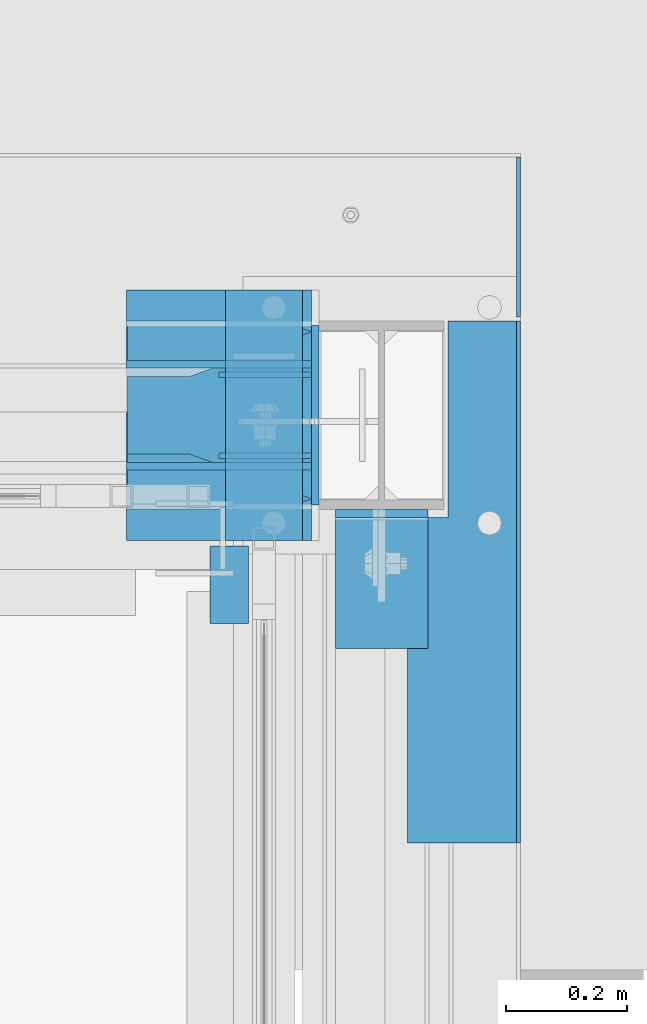
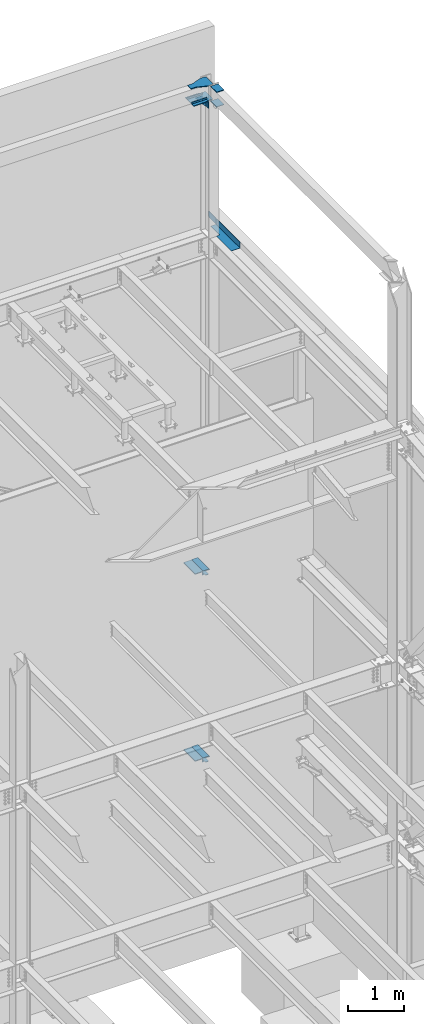
# One storey, part 953 of 1179: 19 beams, 10 elements without a shape of their own.
"""IFC2X3 building model written with IfcOpenShell, lengths in millimetres."""

import ifcopenshell
import ifcopenshell.guid

model = None  # the IFC model being written
_history = None  # IfcOwnerHistory: only IFC2X3 demands one
_inside = {}  # id of a spatial element -> (the spatial element, [elements in it])
_under = {}  # id of a project, library or spatial element -> (it, [spatial elements below it])
_declared = {}  # id of a project -> (the project, [libraries it declares])
_typed = {}  # id of a type object -> (the type object, [elements of that type])
_made_of = {}  # id of a material, layer set ... -> (it, [elements and type objects made of it])


def new_model(schema):
    """Start an empty IFC model of exactly this schema.

    Asked for "IFC4X3", IfcOpenShell would pick the latest addendum, in which some entities
    have other attributes; the version numbers below select the first issue.
    IFC2X3 requires an IfcOwnerHistory on every rooted entity: one is made here for all.
    """
    global model, _history
    if schema == "IFC4X3":
        model = ifcopenshell.file(schema_version=(4, 3, 0, 0))
    else:
        model = ifcopenshell.file(schema=schema)
    _inside.clear()
    _under.clear()
    _declared.clear()
    _typed.clear()
    _made_of.clear()
    _history = None
    if model.schema == "IFC2X3":
        org = make("IfcOrganization", Name="unknown")
        user = make(
            "IfcPersonAndOrganization",
            ThePerson=make("IfcPerson", FamilyName="unknown"),
            TheOrganization=org,
        )
        app = make(
            "IfcApplication",
            ApplicationDeveloper=org,
            Version="unknown",
            ApplicationFullName="unknown",
            ApplicationIdentifier="unknown",
        )
        _history = make(
            "IfcOwnerHistory",
            OwningUser=user,
            OwningApplication=app,
            ChangeAction="ADDED",
            CreationDate=0,
        )
    return model


def make(cls, **values):
    """One entity of the class cls with the attributes given. An attribute that is None is left unset."""
    return model.create_entity(
        cls, **{name: value for name, value in values.items() if value is not None}
    )


def rooted(cls, **values):
    """An entity with a GlobalId (a new one), such as an element, a storey or a relation."""
    return make(cls, GlobalId=ifcopenshell.guid.new(), OwnerHistory=_history, **values)


def si_unit(unit_type, name, prefix=None):
    """IfcSIUnit, for example si_unit("LENGTHUNIT", "METRE", prefix="MILLI")."""
    return make("IfcSIUnit", UnitType=unit_type, Prefix=prefix, Name=name)


def assignment(units):
    """IfcUnitAssignment: the units of a project."""
    return None if units is None else make("IfcUnitAssignment", Units=units)


def point(xyz):
    """IfcCartesianPoint."""
    return None if xyz is None else make("IfcCartesianPoint", Coordinates=xyz)


def direction(xyz):
    """IfcDirection."""
    return None if xyz is None else make("IfcDirection", DirectionRatios=xyz)


def frame(location, z_axis=None, x_axis=None):
    """IfcAxis2Placement3D, a coordinate frame: its origin and axes. An axis left out is left unset."""
    return make(
        "IfcAxis2Placement3D",
        Location=point(location),
        Axis=direction(z_axis),
        RefDirection=direction(x_axis),
    )


def origin_with_axes():
    """The frame at (0, 0, 0) with the z axis (0, 0, 1) and the x axis (1, 0, 0) written out."""
    return frame((0.0, 0.0, 0.0), z_axis=(0.0, 0.0, 1.0), x_axis=(1.0, 0.0, 0.0))


def place(relative_to, where):
    """IfcLocalPlacement: puts the frame where relative to a parent placement (None: the world)."""
    return make(
        "IfcLocalPlacement", PlacementRelTo=relative_to, RelativePlacement=where
    )


def context(
    kind, dimensions, precision=None, world=None, true_north=None, identifier=None
):
    """IfcGeometricRepresentationContext, for example the 3D "Model" context."""
    return make(
        "IfcGeometricRepresentationContext",
        ContextIdentifier=identifier,
        ContextType=kind,
        CoordinateSpaceDimension=dimensions,
        Precision=precision,
        WorldCoordinateSystem=world,
        TrueNorth=true_north,
    )


def subcontext(parent, identifier, kind, view, scale=None):
    """IfcGeometricRepresentationSubContext, for example "Body" below "Model"."""
    return make(
        "IfcGeometricRepresentationSubContext",
        ContextIdentifier=identifier,
        ContextType=kind,
        ParentContext=parent,
        TargetScale=scale,
        TargetView=view,
    )


def project(units=None, contexts=None):
    """IfcProject with its units and contexts."""
    return rooted(
        "IfcProject",
        Name="project",
        RepresentationContexts=contexts,
        UnitsInContext=assignment(units),
    )


def spatial(cls, under=None, at=None, **own):
    """A site, building, storey or space (cls), placed at a placement, below another one or the project."""
    s = rooted(cls, ObjectPlacement=at, **own)
    if under is not None:
        _under.setdefault(under.id(), (under, []))[1].append(s)
    return s


def faces_of(points, faces, orient=None, outer=None):
    """IfcFace entities. A face is a list of loops; a loop is a list of indices into points, from 0.

    orient and outer hold one flag for each loop. By default every Orientation is true, the
    first loop of a face is its IfcFaceOuterBound and the others are IfcFaceBound.
    """
    made = []
    for i, loops in enumerate(faces):
        bounds = []
        for j, loop in enumerate(loops):
            is_outer = j == 0 if outer is None else outer[i][j]
            bounds.append(
                make(
                    "IfcFaceOuterBound" if is_outer else "IfcFaceBound",
                    Bound=make("IfcPolyLoop", Polygon=[points[k] for k in loop]),
                    Orientation=True if orient is None else orient[i][j],
                )
            )
        made.append(make("IfcFace", Bounds=bounds))
    return made


def faceted_brep(points, faces, orient=None, outer=None, voids=None):
    """IfcFacetedBrep: a solid bounded by flat faces; with voids (closed shells), ...WithVoids."""
    shared = [point(p) for p in points]
    hull = make("IfcClosedShell", CfsFaces=faces_of(shared, faces, orient, outer))
    if voids is None:
        return make("IfcFacetedBrep", Outer=hull)
    return make(
        "IfcFacetedBrepWithVoids",
        Outer=hull,
        Voids=[
            make(cls, CfsFaces=faces_of(shared, fs, o, b)) for cls, fs, o, b in voids
        ],
    )


def shape(context_of_items, identifier, shape_type, items):
    """IfcShapeRepresentation: the items that make up one representation, for example the "Body"."""
    return make(
        "IfcShapeRepresentation",
        ContextOfItems=context_of_items,
        RepresentationIdentifier=identifier,
        RepresentationType=shape_type,
        Items=items,
    )


def material(Name=None, Category=None):
    """IfcMaterial."""
    return make("IfcMaterial", Name=Name, Category=Category)


def made_of(thing, what):
    """Note that an element or type object is made of a material, layer set ...; save() writes the relation."""
    if what is not None:
        _made_of.setdefault(what.id(), (what, []))[1].append(thing)
    return thing


def type_object(cls, material=None, **own):
    """A type object (cls), such as IfcWallType, which elements share."""
    return made_of(rooted(cls, **own), material)


def element(
    cls,
    number,
    at=None,
    inside=None,
    cuts=None,
    type_object=None,
    material=None,
    context=None,
    identifier="Body",
    shape_type=None,
    held_by="IfcProductDefinitionShape",
    body=None,
    shapes=None,
    **own,
):
    """One element of the class cls, such as IfcWall. Its Tag is "e" and its number.

    at: its placement. inside: the storey or other place that contains it. cuts: it is an
    opening in that element (IfcRelVoidsElement). A single representation is given by context,
    identifier, shape_type and body (its items); several are given by shapes. held_by: the class
    of the entity that holds the representations. save() writes the other relations.
    """
    e = rooted(cls, Tag="e%d" % number, ObjectPlacement=at, **own)
    if body is not None:
        shapes = [shape(context, identifier, shape_type, body)]
    if shapes is not None:
        e.Representation = make(held_by, Representations=shapes)
    if inside is not None:
        _inside.setdefault(inside.id(), (inside, []))[1].append(e)
    if cuts is not None:
        rooted(
            "IfcRelVoidsElement", RelatingBuildingElement=cuts, RelatedOpeningElement=e
        )
    if type_object is not None:
        _typed.setdefault(type_object.id(), (type_object, []))[1].append(e)
    return made_of(e, material)


def aggregate(whole, parts):
    """IfcRelAggregates: a whole, such as a stair, and the parts it consists of."""
    return rooted("IfcRelAggregates", RelatingObject=whole, RelatedObjects=parts)


def save(model, path):
    """Write the relations noted so far, then the file.

    IfcRelAggregates (storeys below a building ...), IfcRelContainedInSpatialStructure (elements
    in a storey), IfcRelDefinesByType, IfcRelAssociatesMaterial and IfcRelDeclares: one each for
    every whole, place, type object, material and project.
    """
    for whole, parts in _under.values():
        aggregate(whole, parts)
    for where, things in _inside.values():
        rooted(
            "IfcRelContainedInSpatialStructure",
            RelatedElements=things,
            RelatingStructure=where,
        )
    for kind, things in _typed.values():
        rooted("IfcRelDefinesByType", RelatedObjects=things, RelatingType=kind)
    for what, things in _made_of.values():
        rooted("IfcRelAssociatesMaterial", RelatedObjects=things, RelatingMaterial=what)
    for by, libraries in _declared.values():
        rooted("IfcRelDeclares", RelatingContext=by, RelatedDefinitions=libraries)
    model.write(path)


model = new_model("IFC2X3")

# Units and contexts
model_context = context("Model", 3, precision=1e-05, world=origin_with_axes())
body_context = subcontext(model_context, "Body", "Model", "MODEL_VIEW")
ifc_project = project(units=[si_unit("LENGTHUNIT", "METRE", prefix="MILLI"), si_unit("AREAUNIT", "SQUARE_METRE"), si_unit("VOLUMEUNIT", "CUBIC_METRE"), si_unit("MASSUNIT", "GRAM", prefix="KILO"), si_unit("TIMEUNIT", "SECOND"), si_unit("PLANEANGLEUNIT", "RADIAN"), si_unit("SOLIDANGLEUNIT", "STERADIAN"), si_unit("THERMODYNAMICTEMPERATUREUNIT", "DEGREE_CELSIUS"), si_unit("LUMINOUSINTENSITYUNIT", "LUMEN")], contexts=[model_context])

# Site, building, storey
site_placement = place(None, origin_with_axes())
site = spatial("IfcSite", under=ifc_project, at=site_placement, CompositionType="ELEMENT")
building_placement = place(site_placement, origin_with_axes())
building = spatial("IfcBuilding", under=site, at=building_placement, Name="Undefined", CompositionType="ELEMENT")
storey_placement = place(building_placement, origin_with_axes())
storey = spatial("IfcBuildingStorey", under=building, at=storey_placement, Name="Undefined", CompositionType="ELEMENT", Elevation=0.0)

# Assembly, beam
assembly_1_placement = place(storey_placement, origin_with_axes())
assembly_1 = element("IfcElementAssembly", 1, at=assembly_1_placement, inside=storey, Name="BEAM", AssemblyPlace="NOTDEFINED", PredefinedType="RIGID_FRAME")
ifc_material = material(Name="STEEL/A36")
beam_type_1 = type_object("IfcBeamType", PredefinedType="NOTDEFINED")
beam_1_placement = place(assembly_1_placement, frame((24350.663, 40924.1625, 13122.275), z_axis=(0.0, -1.0, 0.0), x_axis=(1.0, 0.0, 0.0)))
beam_1 = element("IfcBeam", 2, at=beam_1_placement, type_object=beam_type_1, material=ifc_material, Name="BENT_PLATE", context=body_context, shape_type="Brep", body=[
    faceted_brep([(66.6744999999974, -3.17499999999927, -106.36250000001), (66.6744999999974, 3.17499999999927, -106.36250000001), (66.6744999999974, 3.17499999999927, -430.212500000001), (66.6744999999974, -3.17499999999927, -430.212500000001), (0.0, -3.17499999999927, -106.36250000001), (0.0, 3.17499999999927, -106.36250000001), (179.387000000002, 3.17499999999927, 430.212500000001), (0.0, 3.17499999999927, 430.212500000001), (0.0, -3.17499999999927, 430.212500000001), (185.737000000001, -3.17499999999927, 430.212500000001), (185.737000000001, 130.175000000001, 430.212500000001), (179.387000000002, 130.175000000001, 430.212500000001), (179.387000000002, 3.17499999999927, -430.212500000001), (179.387000000002, 130.175000000001, -430.212500000001), (185.737000000001, 130.175000000001, -430.212500000001), (185.737000000001, -3.17499999999927, -430.212500000001)], [[[0, 1, 2, 3]], [[4, 5, 1, 0]], [[6, 7, 8, 9, 10, 11]], [[12, 6, 11, 13]], [[10, 14, 13, 11]], [[9, 15, 14, 10]], [[12, 13, 14, 15, 3, 2]], [[7, 6, 12, 2, 1, 5]], [[8, 7, 5, 4]], [[15, 9, 8, 4, 0, 3]]]),
])
aggregate(assembly_1, [beam_1])

# Assembly, beams
assembly_2_placement = place(storey_placement, origin_with_axes())
assembly_2 = element("IfcElementAssembly", 3, at=assembly_2_placement, inside=storey, Name="COLUMN", AssemblyPlace="NOTDEFINED", PredefinedType="RIGID_FRAME")
beam_type_2 = type_object("IfcBeamType", PredefinedType="NOTDEFINED")
beam_2_placement = place(assembly_2_placement, frame((24198.2625, 41346.4375, 16030.575), z_axis=(0.0, 0.0, 1.0), x_axis=(0.0, -1.0, 0.0)))
beam_2 = element("IfcBeam", 4, at=beam_2_placement, type_object=beam_type_2, material=ifc_material, Name="PLATE", context=body_context, shape_type="Brep", body=[
    faceted_brep([(-7.27595761418343e-12, 6.35000000000036, -76.1999999999971), (0.0, 6.35000000000036, 76.2000000000044), (295.274999999994, 6.34999999999854, 76.2000000000007), (295.274999999994, 6.34999999999854, -76.2000000000007), (0.0, -6.35000000000036, 76.2000000000044), (295.274999999994, -6.34999999999854, 76.2000000000007), (7.27595761418343e-12, -6.35000000000036, -76.1999999999971), (295.274999999994, -6.34999999999854, -76.2000000000007)], [[[0, 1, 2, 3]], [[1, 4, 5, 2]], [[4, 6, 7, 5]], [[6, 0, 3, 7]], [[5, 7, 3, 2]], [[6, 4, 1, 0]]]),
])
beam_3_placement = place(assembly_2_placement, frame((24307.8, 40814.6250061035, 16116.3), z_axis=(1.0, 0.0, 0.0), x_axis=(0.0, 1.0, 0.0)))
beam_3 = element("IfcBeam", 5, at=beam_3_placement, type_object=beam_type_2, material=ifc_material, Name="PLATE", context=body_context, shape_type="Brep", body=[
    faceted_brep([(215.900000000001, 6.35000000000036, 76.2000000000007), (228.599999999999, -6.35000000000036, 76.2000000000007), (228.599999999999, -6.35000000000036, -76.2000000000007), (215.900000000001, 6.35000000000036, -76.2000000000007), (-7.27595761418343e-12, 6.35000000000036, -76.1999999999971), (0.0, 6.35000000000036, 76.2000000000044), (0.0, -6.35000000000036, 76.2000000000044), (7.27595761418343e-12, -6.35000000000036, -76.1999999999971)], [[[0, 1, 2, 3]], [[4, 5, 0, 3]], [[5, 6, 1, 0]], [[6, 7, 2, 1]], [[7, 4, 3, 2]], [[7, 6, 5, 4]]]),
])
beam_4_placement = place(assembly_2_placement, frame((24307.8, 40814.6250059853, 16435.3875), z_axis=(1.0, 0.0, 0.0), x_axis=(0.0, 1.0, 0.0)))
beam_4 = element("IfcBeam", 6, at=beam_4_placement, type_object=beam_type_2, material=ifc_material, Name="PLATE", context=body_context, shape_type="Brep", body=[
    faceted_brep([(215.900000000001, 6.35000000000036, 76.2000000000007), (228.599999999999, -6.35000000000036, 76.2000000000007), (228.599999999999, -6.35000000000036, -76.2000000000007), (215.900000000001, 6.35000000000036, -76.2000000000007), (-7.27595761418343e-12, 6.35000000000036, -76.1999999999971), (0.0, 6.35000000000036, 76.2000000000044), (0.0, -6.35000000000036, 76.2000000000044), (7.27595761418343e-12, -6.35000000000036, -76.1999999999971)], [[[0, 1, 2, 3]], [[4, 5, 0, 3]], [[5, 6, 1, 0]], [[6, 7, 2, 1]], [[7, 4, 3, 2]], [[7, 6, 5, 4]]]),
])
beam_type_3 = type_object("IfcBeamType", PredefinedType="NOTDEFINED")
beam_5_placement = place(assembly_2_placement, frame((24039.5125, 40992.425, 5921.375), z_axis=(1.0, 0.0, 0.0), x_axis=(0.0, 1.0, 0.0)))
beam_5 = element("IfcBeam", 7, at=beam_5_placement, type_object=beam_type_3, material=ifc_material, Name="PLATE", context=body_context, shape_type="Brep", body=[
    faceted_brep([(0.0, 9.52500000000146, -152.4), (0.0, 9.52500000000146, 152.4), (412.75, 9.52499999999964, 152.400000000001), (412.75, 9.52499999999964, -152.400000000001), (0.0, -9.52500000000146, 152.4), (412.75, -9.52499999999964, 152.400000000001), (0.0, -9.52500000000146, -152.4), (412.75, -9.52499999999964, -152.400000000001)], [[[0, 1, 2, 3]], [[1, 4, 5, 2]], [[4, 6, 7, 5]], [[6, 0, 3, 7]], [[5, 7, 3, 2]], [[6, 4, 1, 0]]]),
])
beam_6_placement = place(assembly_2_placement, frame((24039.5125, 40992.425, 1835.15), z_axis=(1.0, 0.0, 0.0), x_axis=(0.0, 1.0, 0.0)))
beam_6 = element("IfcBeam", 8, at=beam_6_placement, type_object=beam_type_3, material=ifc_material, Name="PLATE", context=body_context, shape_type="Brep", body=[
    faceted_brep([(0.0, 9.52500000000146, -152.4), (0.0, 9.52500000000146, 152.4), (412.75, 9.52499999999964, 152.400000000001), (412.75, 9.52499999999964, -152.400000000001), (0.0, -9.52500000000146, 152.4), (412.75, -9.52499999999964, 152.400000000001), (0.0, -9.52500000000146, -152.4), (412.75, -9.52499999999964, -152.400000000001)], [[[0, 1, 2, 3]], [[1, 4, 5, 2]], [[4, 6, 7, 5]], [[6, 0, 3, 7]], [[5, 7, 3, 2]], [[6, 4, 1, 0]]]),
])

# Assembly, beam
assembly_3_placement = place(storey_placement, origin_with_axes())
assembly_3 = element("IfcElementAssembly", 9, at=assembly_3_placement, inside=storey, Name="STAIR", AssemblyPlace="NOTDEFINED", PredefinedType="RIGID_FRAME")
beam_type_4 = type_object("IfcBeamType", Name="L5X3X3/8", PredefinedType="NOTDEFINED")
beam_7_placement = place(assembly_3_placement, frame((24025.2250004165, 40919.4, 5899.14999999934), z_axis=(0.0, -1.0, 0.0), x_axis=(1.0, 0.0, 0.0)))
beam_7 = element("IfcBeam", 10, at=beam_7_placement, type_object=beam_type_4, material=ifc_material, Name="ANGLE", ObjectType="L5X3X3/8", context=body_context, shape_type="Brep", body=[
    faceted_brep([(0.0, 38.0999999999985, -63.5), (0.0, 38.1000000000004, 63.5), (63.5, 38.1000000000004, 63.5), (63.5, 38.1000000000004, -63.5), (0.0, 28.5749999999998, 63.5), (63.5, 28.5749999999998, 63.5), (0.0, 28.5749999999998, -53.9749999999985), (63.5, 28.5749999999998, -53.9749999999985), (0.0, -38.1000000000004, -53.9749999999985), (63.5, -38.1000000000004, -53.9749999999985), (0.0, -38.1000000000004, -63.5), (63.5, -38.1000000000004, -63.5)], [[[0, 1, 2, 3]], [[1, 4, 5, 2]], [[4, 6, 7, 5]], [[6, 8, 9, 7]], [[8, 10, 11, 9]], [[10, 0, 3, 11]], [[5, 7, 9, 11, 3, 2]], [[10, 8, 6, 4, 1, 0]]]),
])
aggregate(assembly_3, [beam_7])

assembly_4_placement = place(storey_placement, origin_with_axes())
assembly_4 = element("IfcElementAssembly", 11, at=assembly_4_placement, inside=storey, Name="STAIR", AssemblyPlace="NOTDEFINED", PredefinedType="RIGID_FRAME")
beam_8_placement = place(assembly_4_placement, frame((24025.2250004165, 40919.4, 1812.92499999934), z_axis=(0.0, -1.0, 0.0), x_axis=(1.0, 0.0, 0.0)))
beam_8 = element("IfcBeam", 12, at=beam_8_placement, type_object=beam_type_4, material=ifc_material, Name="ANGLE", ObjectType="L5X3X3/8", context=body_context, shape_type="Brep", body=[
    faceted_brep([(0.0, 38.0999999999985, -63.5), (0.0, 38.1000000000004, 63.5), (63.5, 38.1000000000004, 63.5), (63.5, 38.1000000000004, -63.5), (0.0, 28.5749999999998, 63.5), (63.5, 28.5749999999998, 63.5), (0.0, 28.5749999999998, -53.9749999999985), (63.5, 28.5749999999998, -53.9749999999985), (0.0, -38.1000000000004, -53.9749999999985), (63.5, -38.1000000000004, -53.9749999999985), (0.0, -38.1000000000004, -63.5), (63.5, -38.1000000000004, -63.5)], [[[0, 1, 2, 3]], [[1, 4, 5, 2]], [[4, 6, 7, 5]], [[6, 8, 9, 7]], [[8, 10, 11, 9]], [[10, 0, 3, 11]], [[5, 7, 9, 11, 3, 2]], [[10, 8, 6, 4, 1, 0]]]),
])
aggregate(assembly_4, [beam_8])

assembly_5_placement = place(storey_placement, origin_with_axes())
assembly_5 = element("IfcElementAssembly", 13, at=assembly_5_placement, inside=storey, Name="LAYER", AssemblyPlace="NOTDEFINED", PredefinedType="RIGID_FRAME")
beam_type_5 = type_object("IfcBeamType", PredefinedType="NOTDEFINED")
beam_9_placement = place(assembly_5_placement, frame((24114.125, 40992.425, 5932.4875), z_axis=(1.0, 0.0, 0.0), x_axis=(0.0, 1.0, 0.0)))
beam_9 = element("IfcBeam", 14, at=beam_9_placement, type_object=beam_type_5, material=ifc_material, Name="LAYER", context=body_context, shape_type="Brep", body=[
    faceted_brep([(0.0, 1.58749999999964, -63.5), (0.0, 1.58749999999964, 63.5), (412.75, 1.58749999999964, 63.5), (412.75, 1.58749999999964, -63.5), (0.0, -1.58749999999964, 63.5), (412.75, -1.58749999999964, 63.5), (0.0, -1.58749999999964, -63.5), (412.75, -1.58749999999964, -63.5)], [[[0, 1, 2, 3]], [[1, 4, 5, 2]], [[4, 6, 7, 5]], [[6, 0, 3, 7]], [[5, 7, 3, 2]], [[6, 4, 1, 0]]]),
])
aggregate(assembly_5, [beam_9])

assembly_6_placement = place(storey_placement, origin_with_axes())
assembly_6 = element("IfcElementAssembly", 15, at=assembly_6_placement, inside=storey, Name="LAYER", AssemblyPlace="NOTDEFINED", PredefinedType="RIGID_FRAME")
beam_10_placement = place(assembly_6_placement, frame((24114.125, 40992.425, 5935.6625), z_axis=(1.0, 0.0, 0.0), x_axis=(0.0, 1.0, 0.0)))
beam_10 = element("IfcBeam", 16, at=beam_10_placement, type_object=beam_type_5, material=ifc_material, Name="LAYER", context=body_context, shape_type="Brep", body=[
    faceted_brep([(0.0, 1.58749999999964, -63.5), (0.0, 1.58749999999964, 63.5), (412.75, 1.58749999999964, 63.5), (412.75, 1.58749999999964, -63.5), (0.0, -1.58749999999964, 63.5), (412.75, -1.58749999999964, 63.5), (0.0, -1.58749999999964, -63.5), (412.75, -1.58749999999964, -63.5)], [[[0, 1, 2, 3]], [[1, 4, 5, 2]], [[4, 6, 7, 5]], [[6, 0, 3, 7]], [[5, 7, 3, 2]], [[6, 4, 1, 0]]]),
])
aggregate(assembly_6, [beam_10])

assembly_7_placement = place(storey_placement, origin_with_axes())
assembly_7 = element("IfcElementAssembly", 17, at=assembly_7_placement, inside=storey, Name="LAYER", AssemblyPlace="NOTDEFINED", PredefinedType="RIGID_FRAME")
beam_11_placement = place(assembly_7_placement, frame((24114.125, 40992.425, 1846.2625), z_axis=(1.0, 0.0, 0.0), x_axis=(0.0, 1.0, 0.0)))
beam_11 = element("IfcBeam", 18, at=beam_11_placement, type_object=beam_type_5, material=ifc_material, Name="LAYER", context=body_context, shape_type="Brep", body=[
    faceted_brep([(0.0, 1.58749999999964, -63.5), (0.0, 1.58749999999964, 63.5), (412.75, 1.58749999999964, 63.5), (412.75, 1.58749999999964, -63.5), (0.0, -1.58749999999964, 63.5), (412.75, -1.58749999999964, 63.5), (0.0, -1.58749999999964, -63.5), (412.75, -1.58749999999964, -63.5)], [[[0, 1, 2, 3]], [[1, 4, 5, 2]], [[4, 6, 7, 5]], [[6, 0, 3, 7]], [[5, 7, 3, 2]], [[6, 4, 1, 0]]]),
])
aggregate(assembly_7, [beam_11])

assembly_8_placement = place(storey_placement, origin_with_axes())
assembly_8 = element("IfcElementAssembly", 19, at=assembly_8_placement, inside=storey, Name="LAYER", AssemblyPlace="NOTDEFINED", PredefinedType="RIGID_FRAME")
beam_12_placement = place(assembly_8_placement, frame((24114.125, 40992.425, 1849.4375), z_axis=(1.0, 0.0, 0.0), x_axis=(0.0, 1.0, 0.0)))
beam_12 = element("IfcBeam", 20, at=beam_12_placement, type_object=beam_type_5, material=ifc_material, Name="LAYER", context=body_context, shape_type="Brep", body=[
    faceted_brep([(0.0, 1.58749999999964, -63.5), (0.0, 1.58749999999964, 63.5), (412.75, 1.58749999999964, 63.5), (412.75, 1.58749999999964, -63.5), (0.0, -1.58749999999964, 63.5), (412.75, -1.58749999999964, 63.5), (0.0, -1.58749999999964, -63.5), (412.75, -1.58749999999964, -63.5)], [[[0, 1, 2, 3]], [[1, 4, 5, 2]], [[4, 6, 7, 5]], [[6, 0, 3, 7]], [[5, 7, 3, 2]], [[6, 4, 1, 0]]]),
])
aggregate(assembly_8, [beam_12])

assembly_9_placement = place(storey_placement, origin_with_axes())
assembly_9 = element("IfcElementAssembly", 21, at=assembly_9_placement, inside=storey, Name="BEAM", AssemblyPlace="NOTDEFINED", PredefinedType="RIGID_FRAME")
beam_type_6 = type_object("IfcBeamType", PredefinedType="NOTDEFINED")
beam_13_placement = place(assembly_9_placement, frame((24533.226, 41360.725, 13188.9500061035), z_axis=(0.0, 0.0, 1.0), x_axis=(0.0, 1.0, 0.0)))
beam_13 = element("IfcBeam", 22, at=beam_13_placement, type_object=beam_type_6, material=ifc_material, Name="PLATE", context=body_context, shape_type="Brep", body=[
    faceted_brep([(263.524999994857, -3.17499999999927, -44.4500000000007), (244.474999994854, -3.17499999999927, -63.5), (244.474999994854, 3.17499999999927, -63.5), (263.524999994857, 3.17499999999927, -44.4500000000007), (0.0, 3.17499999999927, -63.5), (0.0, 3.17499999999927, 63.5), (263.524999994857, 3.17499999999927, 63.5), (0.0, -3.17499999999927, 63.5), (263.524999994857, -3.17499999999927, 63.5), (0.0, -3.17499999999927, -63.5)], [[[0, 1, 2, 3]], [[4, 5, 6, 3, 2]], [[5, 7, 8, 6]], [[8, 7, 9, 1, 0]], [[9, 4, 2, 1]], [[6, 8, 0, 3]], [[9, 7, 5, 4]]]),
])
aggregate(assembly_9, [beam_13])

# Beam
beam_type_7 = type_object("IfcBeamType", PredefinedType="NOTDEFINED")
beam_14_placement = place(assembly_2_placement, frame((23887.1125, 41282.9375, 16141.7), z_axis=(0.0, 0.0, 1.0), x_axis=(1.0, 0.0, 0.0)))
beam_14 = element("IfcBeam", 23, at=beam_14_placement, type_object=beam_type_7, material=ifc_material, Name="PLATE", context=body_context, shape_type="Brep", body=[
    faceted_brep([(0.0, 6.34999999999854, -19.0499999999993), (0.0, 6.35000000000036, 19.0499999999993), (317.5, 6.34999999999854, 19.0499999999993), (317.5, 6.34999999999854, -19.0499999999993), (0.0, -6.35000000000036, 19.0499999999993), (317.5, -6.34999999999854, 19.0499999999993), (0.0, -6.34999999999854, -19.0499999999993), (317.5, -6.34999999999854, -19.0499999999993)], [[[0, 1, 2, 3]], [[1, 4, 5, 2]], [[4, 6, 7, 5]], [[6, 0, 3, 7]], [[5, 7, 3, 2]], [[6, 4, 1, 0]]]),
])

beam_15_placement = place(assembly_2_placement, frame((23887.1125, 41114.6625, 16141.7), z_axis=(0.0, 0.0, 1.0), x_axis=(1.0, 0.0, 0.0)))
beam_15 = element("IfcBeam", 24, at=beam_15_placement, type_object=beam_type_7, material=ifc_material, Name="PLATE", context=body_context, shape_type="Brep", body=[
    faceted_brep([(0.0, 6.34999999999854, -19.0499999999993), (0.0, 6.35000000000036, 19.0499999999993), (317.5, 6.34999999999854, 19.0499999999993), (317.5, 6.34999999999854, -19.0499999999993), (0.0, -6.35000000000036, 19.0499999999993), (317.5, -6.34999999999854, 19.0499999999993), (0.0, -6.34999999999854, -19.0499999999993), (317.5, -6.34999999999854, -19.0499999999993)], [[[0, 1, 2, 3]], [[1, 4, 5, 2]], [[4, 6, 7, 5]], [[6, 0, 3, 7]], [[5, 7, 3, 2]], [[6, 4, 1, 0]]]),
])

beam_type_8 = type_object("IfcBeamType", PredefinedType="NOTDEFINED")
beam_16_placement = place(assembly_2_placement, frame((24039.5125, 41265.475, 16030.575), z_axis=(0.0, 0.0, 1.0), x_axis=(1.0, 0.0, 0.0)))
beam_16 = element("IfcBeam", 25, at=beam_16_placement, type_object=beam_type_8, material=ifc_material, Name="PLATE", context=body_context, shape_type="Brep", body=[
    faceted_brep([(152.4, -4.76249999999709, 76.2), (152.4, -4.76249999999709, -76.2), (152.4, 4.76249999999709, -76.2), (152.4, 4.76249999999709, 76.2), (0.0, 4.76249999999982, 76.1999999999971), (0.0, -4.76249999999982, 76.1999999999971)], [[[0, 1, 2, 3]], [[3, 2, 4]], [[4, 5, 0, 3]], [[0, 5, 1]], [[4, 2, 1, 5]]]),
])

beam_17_placement = place(assembly_2_placement, frame((24039.5125, 41132.125, 16030.575), z_axis=(0.0, 0.0, 1.0), x_axis=(1.0, 0.0, 0.0)))
beam_17 = element("IfcBeam", 26, at=beam_17_placement, type_object=beam_type_8, material=ifc_material, Name="PLATE", context=body_context, shape_type="Brep", body=[
    faceted_brep([(152.4, -4.76249999999709, 76.2), (152.4, -4.76249999999709, -76.2), (152.4, 4.76249999999709, -76.2), (152.4, 4.76249999999709, 76.2), (0.0, 4.76249999999982, 76.1999999999971), (0.0, -4.76249999999982, 76.1999999999971)], [[[0, 1, 2, 3]], [[3, 2, 4]], [[4, 5, 0, 3]], [[0, 5, 1]], [[4, 2, 1, 5]]]),
])

beam_type_9 = type_object("IfcBeamType", PredefinedType="NOTDEFINED")
beam_18_placement = place(assembly_2_placement, frame((23888.7, 41198.8, 16114.7125), z_axis=(0.0, -1.0, 0.0), x_axis=(1.0, 0.0, 0.0)))
beam_18 = element("IfcBeam", 27, at=beam_18_placement, type_object=beam_type_9, material=ifc_material, Name="PLATE", context=body_context, shape_type="Brep", body=[
    faceted_brep([(414.337500000005, -7.9375, -115.887500012301), (392.112500000007, -7.9375, -138.112500017691), (392.112500000007, 7.9375, -138.112500017691), (414.337500000005, 7.9375, -115.887500012301), (414.337500000005, 7.9375, 115.887500762939), (392.112500000007, 7.9375, 138.112500762938), (392.112500000007, -7.9375, 138.112500762938), (414.337500000005, -7.9375, 115.887500762939), (241.300006103491, -7.9375, -155.575000000001), (241.300006103491, 7.9375, -155.575000000001), (304.79998778872, 7.9375, -138.112500038278), (304.79998778872, -7.9375, -138.112500038278), (0.0, -7.9375, -155.575000000001), (0.0, -7.9375, 155.575000000001), (0.0, 7.9375, 155.575000000001), (0.0, 7.9375, -155.575000000001), (241.300006103513, -7.9375, 155.575000000001), (241.300006103513, 7.9375, 155.575000000001), (304.799990844724, -7.9375, 138.112500762938), (304.799990844724, 7.9375, 138.112500762938)], [[[0, 1, 2, 3]], [[4, 5, 6, 7]], [[8, 9, 10, 11]], [[11, 10, 2, 1]], [[12, 13, 14, 15]], [[14, 13, 16, 17]], [[18, 19, 17, 16]], [[19, 18, 6, 5]], [[4, 7, 0, 3]], [[10, 9, 15, 14, 17, 19, 5, 4, 3, 2]], [[12, 15, 9, 8]], [[7, 6, 18, 16, 13, 12, 8, 11, 1, 0]]]),
])

aggregate(assembly_2, [beam_14, beam_16, beam_15, beam_17, beam_18, beam_2, beam_3, beam_4, beam_5, beam_6])

# Assembly, beam
assembly_10_placement = place(storey_placement, origin_with_axes())
assembly_10 = element("IfcElementAssembly", 28, at=assembly_10_placement, inside=storey, Name="PLATE", AssemblyPlace="NOTDEFINED", PredefinedType="RIGID_FRAME")
beam_type_10 = type_object("IfcBeamType", PredefinedType="NOTDEFINED")
beam_19_placement = place(assembly_10_placement, frame((23888.7, 41198.8, 16435.3875), z_axis=(0.0, -1.0, 0.0), x_axis=(1.0, 0.0, 0.0)))
beam_19 = element("IfcBeam", 29, at=beam_19_placement, type_object=beam_type_10, material=ifc_material, Name="PLATE", context=body_context, shape_type="Brep", body=[
    faceted_brep([(414.337500000005, -7.9375, -115.887500012301), (392.112500000007, -7.9375, -138.112500017691), (392.112500000007, 7.9375, -138.112500017691), (414.337500000005, 7.9375, -115.887500012301), (414.337500000005, 7.9375, 115.887500762939), (392.112500000007, 7.9375, 138.112500762938), (392.112500000007, -7.9375, 138.112500762938), (414.337500000005, -7.9375, 115.887500762939), (97.0841207160993, -7.9375, 63.4999984741225), (97.0841207160993, 7.9375, 63.4999984741225), (0.0, 7.9375, 63.5), (0.0, -7.9375, 63.5), (99.3158287045953, -7.9375, 63.5982301687436), (99.3158287045953, 7.9375, 63.5982301687436), (101.530274924517, -7.9375, 63.8921654521291), (101.530274924517, 7.9375, 63.8921654521291), (103.710331123249, -7.9375, 64.379530799768), (103.710331123249, 7.9375, 64.379530799768), (105.839135047427, -7.9375, 65.0565565482866), (105.839135047427, 7.9375, 65.0565565482866), (304.799990844724, -7.9375, 138.112500762938), (304.799990844724, 7.9375, 138.112500762938), (0.0, -7.9375, -63.5), (0.0, 7.9375, -63.5), (97.0841208027923, 7.9375, -63.5), (97.0841208027923, -7.9375, -63.5), (99.3158287494298, 7.9375, -63.5982316909285), (99.3158287494298, -7.9375, -63.5982316909285), (101.530274928467, 7.9375, -63.8921669632982), (101.530274928467, -7.9375, -63.8921669632982), (103.710331088252, 7.9375, -64.3795322927581), (103.710331088252, -7.9375, -64.3795322927581), (105.839134976348, 7.9375, -65.0565580162292), (105.839134976348, -7.9375, -65.0565580162292), (304.79998778872, -7.9375, -138.112500038278), (304.79998778872, 7.9375, -138.112500038278)], [[[0, 1, 2, 3]], [[4, 5, 6, 7]], [[8, 9, 10, 11]], [[12, 13, 9, 8]], [[14, 15, 13, 12]], [[16, 17, 15, 14]], [[18, 19, 17, 16]], [[20, 21, 19, 18]], [[22, 23, 24, 25]], [[25, 24, 26, 27]], [[27, 26, 28, 29]], [[29, 28, 30, 31]], [[31, 30, 32, 33]], [[34, 33, 32, 35]], [[34, 35, 2, 1]], [[4, 7, 0, 3]], [[7, 6, 20, 18, 16, 14, 12, 8, 11, 22, 25, 27, 29, 31, 33, 34, 1, 0]], [[22, 11, 10, 23]], [[35, 32, 30, 28, 26, 24, 23, 10, 9, 13, 15, 17, 19, 21, 5, 4, 3, 2]], [[21, 20, 6, 5]]]),
])
aggregate(assembly_10, [beam_19])

save(model, "model.ifc")
